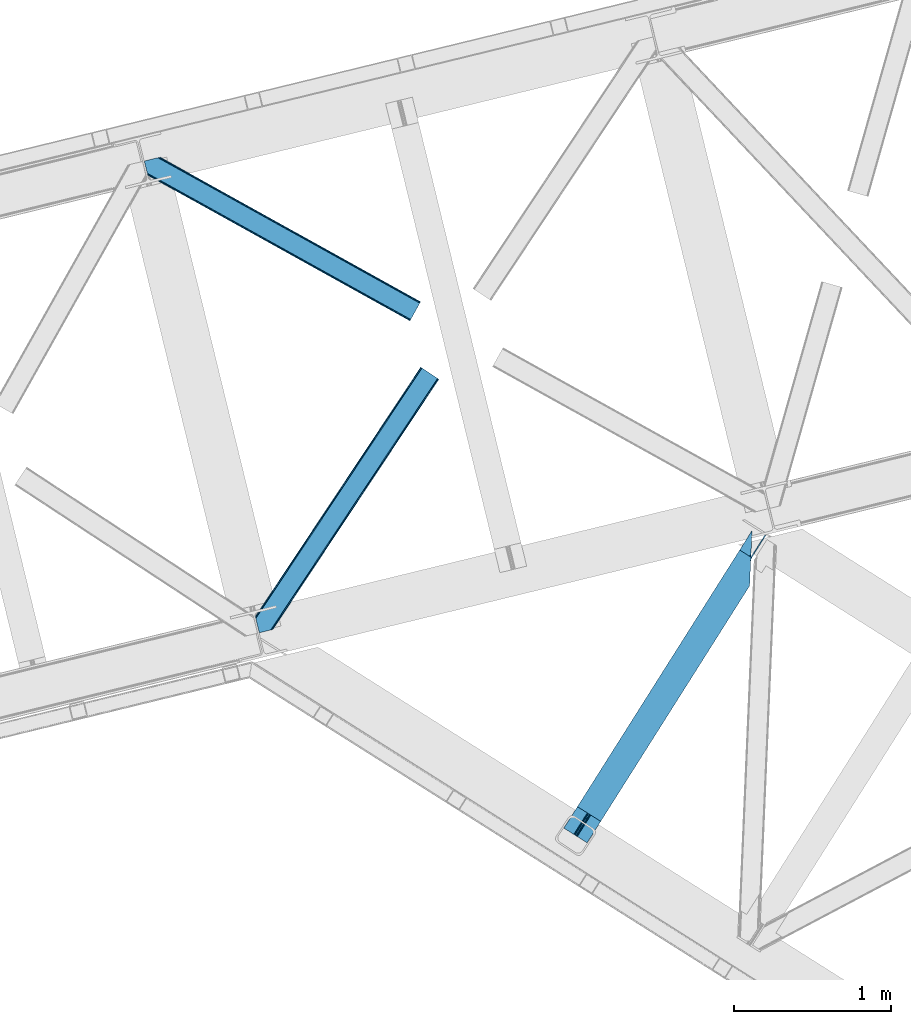
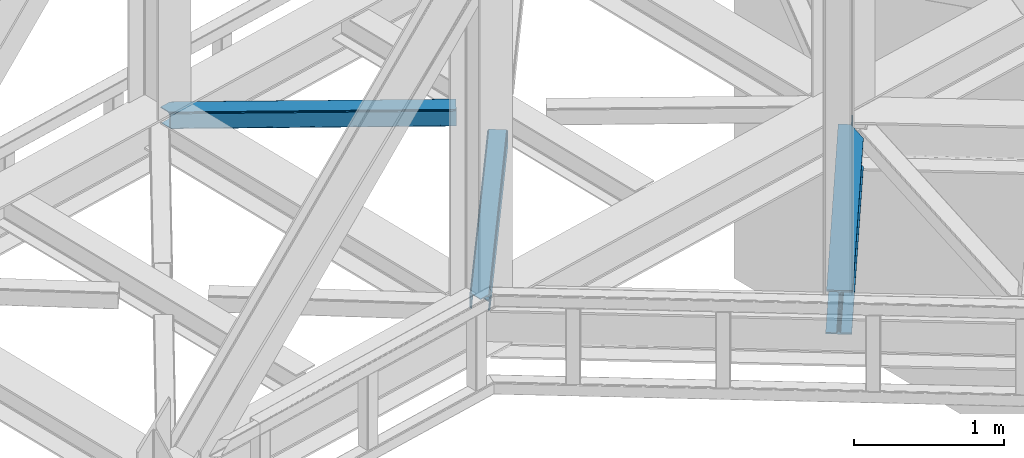
# One storey, part 81 of 93: 2 members, 1 beam.
"""IFC4 building model written with IfcOpenShell, lengths in millimetres."""

from ifc_helpers import new_model, entity, si_unit, converted_unit, derived_unit, direction, frame, origin, place, context, subcontext, project, spatial, triangles, type_object, element, save


model = new_model("IFC4")

# Units and contexts
model_context = context("Model", 3, precision=0.01, world=origin(), true_north=direction((6.12303176911189e-17, 1.0)))
plan_context = context("Plan", 3, precision=0.01, world=origin(), true_north=direction((6.12303176911189e-17, 1.0)))
body_context = subcontext(model_context, "Body", "Model", "MODEL_VIEW")
ifc_project = project(units=[si_unit("LENGTHUNIT", "METRE", prefix="MILLI"), si_unit("AREAUNIT", "SQUARE_METRE"), si_unit("VOLUMEUNIT", "CUBIC_METRE"), converted_unit("PLANEANGLEUNIT", "DEGREE", entity("IfcRatioMeasure", 0.0174532925199433), si_unit("PLANEANGLEUNIT", "RADIAN"), dimensions=[0, 0, 0, 0, 0, 0, 0]), si_unit("MASSUNIT", "GRAM", prefix="KILO"), derived_unit("MASSDENSITYUNIT", [(si_unit("MASSUNIT", "GRAM", prefix="KILO"), 1), (si_unit("LENGTHUNIT", "METRE"), -3)]), derived_unit("MOMENTOFINERTIAUNIT", [(si_unit("LENGTHUNIT", "METRE"), 4)]), si_unit("TIMEUNIT", "SECOND"), si_unit("FREQUENCYUNIT", "HERTZ"), si_unit("THERMODYNAMICTEMPERATUREUNIT", "DEGREE_CELSIUS"), derived_unit("THERMALTRANSMITTANCEUNIT", [(si_unit("MASSUNIT", "GRAM", prefix="KILO"), 1), (si_unit("THERMODYNAMICTEMPERATUREUNIT", "KELVIN"), -1), (si_unit("TIMEUNIT", "SECOND"), -3)]), derived_unit("VOLUMETRICFLOWRATEUNIT", [(si_unit("LENGTHUNIT", "METRE"), 3), (si_unit("TIMEUNIT", "SECOND"), -1)]), derived_unit("MASSFLOWRATEUNIT", [(si_unit("MASSUNIT", "GRAM", prefix="KILO"), 1), (si_unit("TIMEUNIT", "SECOND"), -1)]), derived_unit("ROTATIONALFREQUENCYUNIT", [(si_unit("TIMEUNIT", "SECOND"), -1)]), si_unit("ELECTRICCURRENTUNIT", "AMPERE"), si_unit("ELECTRICVOLTAGEUNIT", "VOLT"), si_unit("POWERUNIT", "WATT"), si_unit("FORCEUNIT", "NEWTON", prefix="KILO"), si_unit("ILLUMINANCEUNIT", "LUX"), si_unit("LUMINOUSFLUXUNIT", "LUMEN"), si_unit("LUMINOUSINTENSITYUNIT", "CANDELA"), derived_unit("USERDEFINED", [(si_unit("MASSUNIT", "GRAM", prefix="KILO"), -1), (si_unit("LENGTHUNIT", "METRE"), -2), (si_unit("TIMEUNIT", "SECOND"), 3), (si_unit("LUMINOUSFLUXUNIT", "LUMEN"), 1)]), derived_unit("LINEARVELOCITYUNIT", [(si_unit("LENGTHUNIT", "METRE"), 1), (si_unit("TIMEUNIT", "SECOND"), -1)]), si_unit("PRESSUREUNIT", "PASCAL"), derived_unit("USERDEFINED", [(si_unit("LENGTHUNIT", "METRE"), -2), (si_unit("MASSUNIT", "GRAM", prefix="KILO"), 1), (si_unit("TIMEUNIT", "SECOND"), -2)]), derived_unit("LINEARFORCEUNIT", [(si_unit("MASSUNIT", "GRAM", prefix="KILO"), 1), (si_unit("LENGTHUNIT", "METRE"), 1), (si_unit("TIMEUNIT", "SECOND"), -2), (si_unit("LENGTHUNIT", "METRE"), -1)]), derived_unit("PLANARFORCEUNIT", [(si_unit("MASSUNIT", "GRAM", prefix="KILO"), 1), (si_unit("LENGTHUNIT", "METRE"), 1), (si_unit("TIMEUNIT", "SECOND"), -2), (si_unit("LENGTHUNIT", "METRE"), -2)])], contexts=[model_context, plan_context])

# Site, building, storey
site_placement = place(None, origin())
site = spatial("IfcSite", under=ifc_project, at=site_placement, CompositionType="ELEMENT")
building_placement = place(site_placement, origin())
building = spatial("IfcBuilding", under=site, at=building_placement, CompositionType="ELEMENT")
storey_placement = place(building_placement, frame((0.0, 0.0, 15900.0)))
storey = spatial("IfcBuildingStorey", under=building, at=storey_placement, CompositionType="ELEMENT", Elevation=15900.0)

# Beam
beam_type = type_object("IfcBeamType", PredefinedType="BEAM")
beam_placement = place(storey_placement, frame((-3471.97848129272, 14954.9604217529, 3440.99967956543)))
element("IfcBeam", 1, at=beam_placement, inside=storey, type_object=beam_type, ObjectType="Steel Beam", PredefinedType="BEAM", context=body_context, shape_type="Tessellation", body=[
    triangles([(1188.72613334656, 1816.41354675293, 231.001016235354), (1188.08329467773, 1793.75679016113, 228.315133666994), (1188.92815589905, 1796.73218994141, 227.02451477051), (1187.41618423462, 1786.02702941895, 231.001016235354), (1190.21528663635, 1815.46941833496, 227.191946411134), (1191.30315628052, 1805.13516540527, 223.385202026369), (1194.96863021851, 1812.46611328125, 221.003952026367), (1191.70894546509, 1814.52645263672, 223.385202026369), (1191.71897392273, 1805.96185913086, 223.115451049805), (163.219397735596, 181.395904541016, 216.999545288087), (1194.53856925964, 1812.73818969727, 216.999545288087), (164.249276733398, 180.744781494141, 223.122427368166), (167.180783843994, 178.891406250001, 228.315133666994), (1187.27709388733, 1782.76792602539, 231.782363891602), (1186.75067253113, 1770.47332763672, 233.000894165041), (171.567144012451, 176.117156982422, 231.782363891602), (176.744734954834, 172.846426391601, 233.000894165041), (1180.87254295349, 1633.92584838867, 233.000894165041), (234.219715118408, 136.50910949707, 233.000894165041), (1188.72613334656, 1816.41354675293, 244.000222778323), (1180.87254295349, 1633.92584838867, 244.000222778323), (234.219715118408, 136.50910949707, 244.000222778323), (1117.61957244873, 1861.36429138184, 244.000222778323), (86.3005462646483, 230.022006225587, 244.000222778323), (1117.61957244873, 1861.36429138184, 233.000894165041), (86.3005462646483, 230.022006225587, 233.000894165041), (1175.09905815125, 1825.02813720703, 233.000894165041), (143.779886627197, 193.685852050781, 233.000894165041), (1187.59422569275, 1817.12978210449, 223.122427368166), (1188.62410469055, 1816.47865905762, 216.999545288087), (157.300572967529, 185.135211181641, 216.999545288087), (156.270693969726, 185.786334228516, 223.122427368166), (1184.66271858215, 1818.98315734863, 228.315133666994), (153.339186859131, 187.639709472656, 228.315133666994), (1180.27214355469, 1821.75624389649, 231.782363891602), (148.953117370605, 190.413958740235, 231.782363891602), (1188.62410469055, 1816.47865905762, 204.000338745118), (1194.53856925964, 1812.73818969727, 204.000338745118), (163.219397735596, 181.395904541016, 204.000338745118), (157.300572967529, 185.135211181641, 204.000338745118), (1284.44601745605, 1954.95276489258, 203.000399780274), (1278.52704734802, 1958.6920715332, 203.000399780274), (1195.07443771362, 1813.58348693848, 203.000399780274), (1189.15546760559, 1817.32395629883, 203.000399780274), (1284.44601745605, 1954.95276489258, 120.000814819337), (1278.52704734802, 1958.6920715332, 120.000814819337), (162.88715057373, 180.872680664063, 203.058535766602), (156.76921005249, 184.291076660156, 203.000399780274), (76.9188514709472, 44.8867950439453, 203.000399780274), (71.0000267028809, 48.626101684571, 203.000399780274), (1200.5501209259, 1835.34494934082, 120.000814819337), (1199.94579734802, 1821.28883056641, 120.000814819337), (1196.02728652954, 1828.19306030274, 119.163656616212), (1195.42281761169, 1814.13694152832, 119.163656616212), (1192.19612503052, 1822.13180236816, 116.778918457032), (1191.59180145264, 1808.07568359375, 116.778918457032), (1189.63639755249, 1818.08088684082, 113.210531616212), (1189.03192863464, 1804.02476806641, 113.210531616212), (1188.73383636475, 1816.65771789551, 109.000323486329), (1188.12951278687, 1802.6015991211, 109.000323486329), (1188.95184631348, 1817.00072021484, 203.077139282228), (1188.73383636475, 1816.65771789551, 27.0006774902358), (71.0000267028809, 48.626101684571, 27.0006774902358), (1189.59076080322, 1836.49139099121, 12.2178588867209), (1190.11718215942, 1848.78598937988, 11.0004913330085), (57.4793403625486, 57.1779052734382, 11.0004913330085), (62.6525711059571, 53.9048492431648, 12.2178588867209), (1189.13977088928, 1826.06760864258, 15.6862518310554), (67.0432914733888, 51.1317626953132, 15.6862518310554), (1188.84124259949, 1819.10291748047, 20.877795410157), (69.9747985839845, 49.2783874511715, 20.877795410157), (1195.99080619812, 1985.3323059082, 11.0004913330085), (0.0, 93.5140594482418, 11.0004913330085), (1195.99080619812, 1985.3323059082, 0.0), (0.0, 93.5140594482418, 0.0), (1180.87254295349, 1633.92584838867, 0.0), (147.91916885376, 0.0, 0.0), (85.2665977478027, 39.6080474853516, 12.2178588867209), (80.8802375793457, 42.3822967529304, 15.6862518310554), (76.9188514709472, 44.8867950439453, 27.0006774902358), (77.94873046875, 44.2356719970703, 20.877795410157), (90.4441886901855, 36.3373168945309, 11.0004913330085), (147.91916885376, 0.0, 11.0004913330085), (1187.27709388733, 1782.76792602539, 12.2178588867209), (1186.75067253113, 1770.47332763672, 11.0004913330085), (1188.02661209106, 1800.15639953613, 20.877795410157), (1187.7279384613, 1793.19170837402, 15.6862518310554), (1188.12951278687, 1802.6015991211, 27.0006774902358), (1180.87254295349, 1633.92584838867, 11.0004913330085)], [[1, 2, 3], [1, 4, 2], [5, 3, 6], [7, 8, 9], [6, 9, 8], [6, 8, 5], [3, 5, 1], [10, 11, 9], [11, 7, 9], [12, 9, 6], [6, 13, 12], [6, 3, 13], [2, 13, 3], [13, 4, 14], [13, 2, 4], [14, 15, 16], [17, 16, 15], [14, 16, 13], [9, 12, 10], [15, 18, 17], [19, 17, 18], [20, 14, 4], [14, 20, 15], [4, 1, 20], [21, 15, 20], [21, 18, 15], [18, 21, 22], [22, 19, 18], [21, 23, 24], [23, 21, 20], [24, 22, 21], [23, 25, 24], [26, 24, 25], [25, 27, 28], [28, 26, 25], [29, 30, 31], [31, 32, 29], [33, 29, 34], [32, 34, 29], [35, 33, 34], [34, 36, 35], [27, 35, 36], [36, 28, 27], [1, 35, 20], [8, 7, 11], [30, 11, 37], [37, 11, 38], [8, 29, 5], [11, 30, 8], [5, 33, 1], [27, 20, 35], [33, 5, 29], [30, 29, 8], [33, 35, 1], [27, 23, 20], [23, 27, 25], [13, 16, 36], [17, 22, 24], [19, 22, 17], [16, 17, 28], [10, 12, 32], [12, 13, 32], [39, 10, 40], [34, 13, 36], [24, 28, 17], [28, 36, 16], [24, 26, 28], [32, 31, 10], [31, 40, 10], [34, 32, 13], [41, 42, 43], [44, 43, 42], [41, 45, 42], [46, 42, 45], [47, 48, 49], [50, 49, 48], [46, 45, 51], [52, 51, 45], [51, 52, 53], [54, 53, 52], [53, 54, 55], [56, 55, 54], [57, 55, 56], [56, 58, 57], [59, 57, 58], [58, 60, 59], [57, 37, 61], [57, 61, 55], [53, 55, 61], [42, 46, 51], [51, 61, 42], [61, 51, 53], [62, 48, 59], [59, 48, 31], [63, 48, 62], [63, 50, 48], [31, 37, 59], [59, 37, 57], [31, 30, 37], [64, 65, 66], [66, 67, 64], [68, 64, 67], [67, 69, 68], [70, 68, 69], [69, 71, 70], [62, 70, 71], [71, 63, 62], [65, 72, 73], [73, 66, 65], [72, 74, 75], [75, 73, 72], [74, 76, 75], [77, 75, 76], [78, 79, 67], [80, 71, 81], [79, 81, 69], [80, 49, 63], [82, 75, 77], [77, 83, 82], [82, 78, 66], [67, 79, 69], [71, 80, 63], [50, 63, 49], [71, 69, 81], [75, 82, 66], [67, 66, 78], [73, 75, 66], [68, 64, 84], [65, 74, 76], [72, 74, 65], [64, 65, 85], [62, 70, 86], [70, 68, 87], [59, 62, 88], [87, 68, 84], [76, 85, 65], [85, 84, 64], [76, 89, 85], [86, 88, 62], [88, 60, 59], [87, 86, 70], [86, 88, 80], [80, 81, 86], [87, 86, 81], [81, 79, 87], [84, 87, 79], [79, 78, 84], [85, 84, 78], [78, 82, 85], [89, 85, 82], [82, 83, 89], [76, 89, 77], [83, 77, 89]]),
])

# Members
member_type_1 = type_object("IfcMemberType", PredefinedType="BRACE")
member_1_placement = place(storey_placement, frame((-5433.35323791504, 16290.2998443604, 3510.01988525391)))
element("IfcMember", 2, at=member_1_placement, inside=storey, type_object=member_type_1, ObjectType="Steel Horizontal Brace", PredefinedType="BRACE", context=body_context, shape_type="Tessellation", body=[
    triangles([(1167.55605926514, 1611.29350891113, 17.5000946044929), (1167.55605926514, 1611.29350891113, 122.499499511719), (112.764628601074, 21.275445556641, 17.5000946044929), (112.764628601074, 21.275445556641, 122.499499511719), (1166.44769668579, 1612.03067321777, 129.196765136719), (110.858349609375, 20.810357666016, 129.196765136719), (1163.28451766968, 1614.12705688477, 134.87548828125), (105.426704406738, 19.486019897462, 134.87548828125), (1158.55573654175, 1617.26640014649, 138.668280029298), (97.3022003173828, 17.5059082031257, 138.668280029298), (1152.97613525391, 1620.96849975586, 140.000756835936), (87.713832092285, 15.1688415527351, 140.000756835936), (5.64326019287091, 81.3950317382823, 140.000756835936), (1065.47537155151, 1679.01263122559, 140.000756835936), (25.4839096069336, 0.0, 140.000756835936), (1059.89577026367, 1682.71473083496, 138.668280029298), (3.48350830078107, 90.2537933349613, 138.668280029298), (1055.16698913574, 1685.85407409668, 134.87548828125), (1.65280609130878, 97.7649627685551, 134.87548828125), (1052.00381011963, 1687.95045776367, 129.196765136719), (0.42962493896448, 102.7832611084, 129.196765136719), (1050.89573822022, 1688.68762207031, 122.499499511719), (0.0, 104.544781494142, 122.499499511719), (1050.89573822022, 1688.68762207031, 17.5000946044929), (0.0, 104.544781494142, 17.5000946044929), (1166.44769668579, 1612.03067321777, 10.8039916992202), (1163.28451766968, 1614.12705688477, 5.12643127441333), (159.822802734375, 95.9557708740231, 9.25873718261573), (160.257078552246, 97.3742889404293, 8.50064392089917), (159.407711791992, 100.858959960939, 5.12643127441333), (110.469419860839, 20.7150146484382, 10.8702667236321), (109.995030212403, 20.5999053955074, 9.50058288574292), (1152.97613525391, 1620.96849975586, 0.0), (1158.55573654175, 1617.26640014649, 1.33247680664135), (155.417839050293, 117.227728271484, 0.0), (157.577009582519, 108.368966674805, 1.33247680664135), (1065.47537155151, 1679.01263122559, 0.0), (121.558859252929, 256.129714965822, 0.0), (155.314356994629, 113.429122924807, 9.50058288574292), (90.5967956542972, 15.8711242675781, 9.50058288574292), (155.425978088379, 114.267443847655, 9.29594421386719), (155.539343261718, 115.1185546875, 9.08781738281323), (160.118714904786, 96.9219909667972, 8.74248962402271), (155.650964355469, 115.956875610353, 8.8831787109375), (155.446325683593, 117.1102935791, 8.50064392089917), (1152.72004623413, 1621.13593139648, 8.3320495605476), (1147.14073562622, 1624.83803100586, 7.00073547363354), (153.160418701172, 126.488790893554, 7.00073547363354), (1157.45347824097, 1617.99775085449, 12.1260040283196), (95.4092926025387, 17.0443084716808, 12.1260040283196), (1161.72501983643, 1615.16420288086, 24.5008300781265), (1160.61200637817, 1615.90020446777, 17.8035644531265), (102.742565917969, 18.8325714111324, 24.5008300781265), (100.835705566406, 18.3674835205074, 17.8035644531265), (1161.72501983643, 1615.16420288086, 115.499926757813), (102.742565917969, 18.8325714111324, 115.499926757813), (100.835705566406, 18.3674835205074, 122.197192382813), (87.2801376342777, 15.0630340576172, 131.668707275392), (77.6917694091799, 12.7259674072266, 133.00118408203), (25.4839096069336, 0.0, 133.00118408203), (95.4092926025387, 17.0443084716808, 127.875915527344), (1147.14073562622, 1624.83803100586, 133.00118408203), (1152.72004623413, 1621.13593139648, 131.668707275392), (1157.45347824097, 1617.99775085449, 127.875915527344), (1160.61200637817, 1615.90020446777, 122.197192382813), (7.90068054199219, 72.1351318359375, 133.00118408203), (1071.3107711792, 1675.14309997558, 133.00118408203), (1056.72648696899, 1684.81692810058, 115.499926757813), (1057.83950042725, 1684.0820892334, 122.197192382813), (2.25742034912128, 95.2848815917987, 115.499926757813), (2.68704528808576, 93.5233612060547, 122.197192382813), (1060.99802856445, 1681.98338012695, 127.875915527344), (3.91022644043005, 88.505062866212, 127.875915527344), (1065.73146057129, 1678.84636230469, 131.668707275392), (5.74092864990234, 80.9938934326183, 131.668707275392), (1060.99802856445, 1681.98338012695, 12.1260040283196), (1059.89577026367, 1682.71473083496, 1.33247680664135), (1055.16698913574, 1685.85407409668, 5.12643127441333), (1071.3107711792, 1675.14309997558, 7.00073547363354), (1065.73146057129, 1678.84636230469, 8.3320495605476), (1056.72648696899, 1684.81692810058, 24.5008300781265), (1052.00381011963, 1687.95045776367, 10.8039916992202), (1057.83950042725, 1684.0820892334, 17.8035644531265), (2.25742034912128, 95.2848815917987, 24.5008300781265), (123.816279602051, 246.869815063475, 7.00073547363354), (2.88121948242224, 92.7245727539066, 16.5001556396492), (2.77483062744159, 93.1629180908203, 17.8698394775383), (0.0093017578128638, 104.50757446289, 16.5001556396492), (119.399688720703, 264.988476562501, 1.33247680664135), (121.662922668457, 255.702996826172, 8.41343994140698), (117.568986511231, 272.499645996095, 5.12643127441333), (116.719619750977, 275.983154296877, 8.50064392089917), (4.73924560546857, 108.865447998049, 10.8714294433594), (115.787118530274, 275.584341430664, 9.50058288574292), (5.89266357421911, 109.927011108399, 9.50058288574292), (7.20479278564471, 93.4687133789066, 12.1260040283196), (120.157200622559, 257.658691406252, 9.50058288574292), (121.184463500977, 256.801766967774, 8.80643920898365), (10.2621643066404, 92.0013610839851, 9.50058288574292)], [[1, 2, 3], [4, 3, 2], [2, 5, 4], [6, 4, 5], [5, 7, 6], [8, 6, 7], [7, 9, 8], [10, 8, 9], [9, 11, 10], [12, 10, 11], [11, 13, 12], [11, 14, 13], [13, 15, 12], [14, 16, 17], [17, 13, 14], [16, 18, 19], [19, 17, 16], [18, 20, 21], [21, 19, 18], [20, 22, 23], [23, 21, 20], [22, 24, 23], [25, 23, 24], [26, 1, 3], [27, 28, 29], [29, 30, 27], [26, 31, 28], [28, 27, 26], [31, 32, 28], [33, 34, 35], [36, 35, 34], [34, 27, 36], [30, 36, 27], [3, 31, 26], [37, 33, 38], [35, 38, 33], [39, 28, 32], [32, 40, 39], [39, 41, 28], [41, 42, 43], [42, 44, 43], [44, 45, 29], [46, 47, 48], [49, 46, 45], [45, 44, 49], [49, 42, 41], [42, 49, 44], [41, 39, 49], [49, 39, 50], [40, 50, 39], [48, 45, 46], [51, 52, 53], [54, 53, 52], [52, 49, 54], [50, 54, 49], [55, 51, 53], [53, 56, 55], [57, 4, 6], [58, 10, 12], [15, 59, 12], [59, 15, 60], [59, 58, 12], [61, 10, 58], [61, 57, 8], [8, 10, 61], [6, 8, 57], [53, 3, 4], [50, 32, 54], [57, 56, 4], [50, 40, 32], [53, 54, 3], [56, 53, 4], [31, 3, 54], [54, 32, 31], [62, 63, 58], [58, 59, 62], [63, 64, 61], [61, 58, 63], [64, 65, 57], [57, 61, 64], [65, 55, 56], [56, 57, 65], [62, 66, 67], [66, 62, 59], [60, 66, 59], [68, 69, 70], [71, 70, 69], [69, 72, 71], [73, 71, 72], [72, 74, 73], [75, 73, 74], [74, 67, 75], [66, 75, 67], [26, 49, 52], [51, 2, 1], [26, 52, 1], [26, 27, 49], [52, 51, 1], [49, 27, 34], [47, 33, 37], [33, 46, 34], [46, 33, 47], [46, 49, 34], [5, 64, 7], [55, 2, 51], [2, 65, 5], [65, 2, 55], [5, 65, 64], [11, 62, 14], [9, 7, 64], [64, 63, 9], [63, 62, 11], [11, 9, 63], [76, 77, 78], [37, 79, 47], [37, 80, 79], [80, 37, 77], [76, 80, 77], [81, 24, 22], [82, 83, 76], [78, 82, 76], [83, 82, 24], [81, 83, 24], [16, 72, 18], [14, 62, 67], [67, 74, 14], [74, 72, 16], [16, 14, 74], [20, 18, 72], [22, 68, 81], [69, 22, 20], [22, 69, 68], [69, 20, 72], [81, 68, 84], [70, 84, 68], [47, 79, 85], [85, 48, 47], [75, 66, 13], [66, 15, 13], [66, 60, 15], [17, 75, 13], [73, 17, 19], [73, 75, 17], [86, 87, 88], [23, 70, 71], [71, 19, 21], [19, 71, 73], [21, 23, 71], [23, 84, 70], [25, 88, 87], [25, 84, 23], [84, 25, 87], [85, 38, 48], [89, 90, 91], [90, 89, 38], [91, 90, 92], [38, 85, 90], [48, 38, 35], [36, 45, 35], [45, 36, 30], [35, 45, 48], [30, 29, 45], [24, 82, 93], [93, 25, 24], [94, 93, 82], [94, 95, 93], [78, 91, 92], [92, 82, 78], [92, 94, 82], [78, 77, 91], [89, 91, 77], [77, 37, 89], [38, 89, 37], [93, 88, 25], [83, 81, 84], [83, 86, 96], [83, 87, 86], [80, 97, 98], [76, 96, 97], [97, 80, 76], [96, 99, 97], [79, 80, 90], [90, 85, 79], [96, 76, 83], [84, 87, 83], [95, 96, 93], [95, 99, 96], [96, 88, 93], [86, 88, 96], [94, 97, 95], [99, 95, 97]]),
])
member_type_2 = type_object("IfcMemberType", PredefinedType="BRACE")
member_2_placement = place(storey_placement, frame((-6138.83285064697, 18272.4951324463, 3510.01988525391)))
element("IfcMember", 3, at=member_2_placement, inside=storey, type_object=member_type_2, ObjectType="Steel Horizontal Brace", PredefinedType="BRACE", context=body_context, shape_type="Tessellation", body=[
    triangles([(1747.75785369873, 107.098114013672, 140.000756835936), (1751.00765533447, 112.952407836914, 138.668280029298), (86.0110290527336, 1037.46574401855, 138.668280029298), (76.4226608276367, 1035.12867736816, 140.000756835936), (1753.76620788574, 117.917221069336, 134.87548828125), (94.1355331420891, 1039.44585571289, 134.87548828125), (1755.6050491333, 121.232135009766, 129.196765136719), (99.5665969848633, 1040.77019348145, 129.196765136719), (1756.25442810059, 122.398342895507, 122.499499511719), (101.473457336426, 1041.23528137207, 122.499499511719), (1756.25442810059, 122.398342895507, 17.5000946044929), (101.473457336426, 1041.23528137207, 17.5000946044929), (1696.78712768555, 15.3002288818352, 140.000756835936), (16.6437515258785, 948.220028686523, 140.000756835936), (0.0, 1016.49958190918, 140.000756835936), (1688.29055328369, 0.0, 122.499499511719), (1688.935572052, 1.16504516601708, 129.196765136719), (22.2870117187495, 925.070278930663, 122.499499511719), (21.857386779785, 926.831799316406, 129.196765136719), (1690.77906417847, 4.48112182617115, 134.87548828125), (20.6342056274407, 931.85009765625, 134.87548828125), (1693.5326751709, 9.44477233886937, 138.668280029298), (18.8035034179684, 939.361267089844, 138.668280029298), (1688.29055328369, 0.0, 17.5000946044929), (22.2870117187495, 925.070278930663, 17.5000946044929), (1753.76620788574, 117.917221069336, 5.12643127441333), (1751.00765533447, 112.952407836914, 1.33247680664135), (163.947550964355, 994.188153076171, 1.33247680664135), (162.329626464843, 1000.82728271484, 4.50088806152417), (1755.6050491333, 121.232135009766, 10.8039916992202), (161.571533203125, 1001.83419799805, 5.00085754394604), (160.809370422363, 1002.84111328125, 5.50082702636792), (99.5665969848633, 1040.77019348145, 10.8039916992202), (94.6552688598631, 1039.57259216309, 5.50082702636792), (1747.75785369873, 107.098114013672, 0.0), (166.107302856445, 985.329391479492, 0.0), (1696.78712768555, 15.3002288818352, 0.0), (199.965701293945, 846.428567504885, 0.0), (203.74395904541, 830.930676269531, 4.50088806152417), (202.125453186035, 837.568643188479, 1.33247680664135), (22.0515609741205, 926.03533630371, 12.5003997802742), (23.5985595703123, 926.191140747073, 10.9621215820298), (1688.935572052, 1.16504516601708, 10.8039916992202), (202.882965087891, 830.238858032226, 5.50082702636792), (1690.77906417847, 4.48112182617115, 5.12643127441333), (29.0836898803709, 926.742269897462, 5.50082702636792), (1693.5326751709, 9.44477233886937, 1.33247680664135), (6.80074768066333, 1018.15762023926, 5.50082702636792), (20.9359313964842, 953.845266723634, 7.00073547363354), (21.5068267822262, 945.865521240234, 8.3320495605476), (5.34560394287109, 1017.80299072266, 7.00073547363354), (18.4942199707029, 940.629794311524, 12.5003997802742), (1700.1831413269, 21.4196228027358, 7.00073547363354), (66.4005981445307, 1032.68580322266, 7.00073547363354), (1744.36184005737, 100.978720092775, 7.00073547363354), (1694.17478713989, 10.6005157470718, 12.1260040283196), (1696.93333969116, 15.5653289794936, 8.3320495605476), (19.5999664306637, 936.091699218752, 17.8035644531265), (1691.69092712402, 6.12055664062427, 24.5008300781265), (1692.33594589233, 7.28443908691406, 17.8035644531265), (20.0295913696282, 934.33017883301, 24.5008300781265), (1747.61164169311, 106.833013916017, 8.3320495605476), (75.9889663696285, 1035.02286987305, 8.3320495605476), (1750.36554336548, 111.796664428712, 12.1260040283196), (84.1175399780268, 1037.00414428711, 12.1260040283196), (1752.20903549194, 115.112741088869, 17.8035644531265), (89.5445343017573, 1038.32731933594, 17.8035644531265), (1752.85405426025, 116.277786254883, 24.5008300781265), (91.4560455322262, 1038.79240722656, 24.5008300781265), (1752.85405426025, 116.277786254883, 115.499926757813), (91.4560455322262, 1038.79240722656, 115.499926757813), (84.1175399780268, 1037.00414428711, 127.875915527344), (75.9889663696285, 1035.02286987305, 131.668707275392), (89.5445343017573, 1038.32731933594, 122.197192382813), (66.4005981445307, 1032.68580322266, 133.00118408203), (0.0, 1016.49958190918, 133.00118408203), (1752.20903549194, 115.112741088869, 122.197192382813), (1750.36554336548, 111.796664428712, 127.875915527344), (1747.61164169311, 106.833013916017, 131.668707275392), (1744.36184005737, 100.978720092775, 133.00118408203), (1694.17478713989, 10.6005157470718, 127.875915527344), (1700.1831413269, 21.4196228027358, 133.00118408203), (1696.93333969116, 15.5653289794936, 131.668707275392), (1691.69092712402, 6.12055664062427, 115.499926757813), (1692.33594589233, 7.28443908691406, 122.197192382813), (19.5999664306637, 936.091699218752, 122.197192382813), (18.3767852783203, 941.109997558593, 127.875915527344), (20.0295913696282, 934.33017883301, 115.499926757813), (16.5460830688471, 948.621166992187, 131.668707275392), (14.3869125366209, 957.479928588869, 133.00118408203)], [[1, 2, 3], [3, 4, 1], [2, 5, 6], [6, 3, 2], [5, 7, 8], [8, 6, 5], [7, 9, 10], [10, 8, 7], [9, 11, 10], [12, 10, 11], [13, 4, 14], [4, 13, 1], [15, 14, 4], [16, 17, 18], [19, 18, 17], [17, 20, 19], [21, 19, 20], [20, 22, 21], [23, 21, 22], [22, 13, 23], [14, 23, 13], [24, 16, 25], [18, 25, 16], [26, 27, 28], [28, 29, 26], [30, 26, 31], [30, 32, 33], [34, 33, 32], [29, 31, 26], [27, 35, 36], [36, 28, 27], [11, 30, 12], [33, 12, 30], [35, 37, 38], [38, 36, 35], [29, 36, 38], [36, 29, 28], [38, 39, 29], [39, 38, 40], [24, 41, 42], [24, 25, 41], [43, 42, 44], [44, 45, 43], [42, 46, 44], [47, 45, 44], [37, 47, 40], [40, 38, 37], [39, 40, 47], [42, 43, 24], [46, 34, 32], [34, 46, 48], [32, 44, 46], [46, 49, 48], [49, 46, 50], [51, 48, 49], [52, 50, 46], [42, 41, 52], [42, 52, 46], [53, 54, 49], [54, 53, 55], [51, 49, 54], [56, 57, 50], [56, 52, 58], [59, 60, 61], [58, 61, 60], [58, 60, 56], [50, 52, 56], [57, 53, 50], [49, 50, 53], [55, 62, 63], [63, 54, 55], [62, 64, 65], [65, 63, 62], [64, 66, 67], [67, 65, 64], [66, 68, 69], [69, 67, 66], [68, 70, 71], [71, 69, 68], [72, 73, 3], [6, 72, 3], [74, 6, 8], [74, 10, 71], [6, 74, 72], [10, 74, 8], [73, 4, 3], [15, 75, 76], [15, 4, 75], [73, 75, 4], [10, 69, 71], [34, 65, 67], [67, 69, 12], [12, 69, 10], [67, 33, 34], [33, 67, 12], [48, 54, 34], [54, 63, 34], [63, 65, 34], [48, 51, 54], [70, 77, 71], [74, 71, 77], [77, 78, 74], [72, 74, 78], [78, 79, 72], [73, 72, 79], [79, 80, 73], [75, 73, 80], [7, 78, 77], [70, 11, 9], [7, 77, 9], [7, 5, 78], [77, 70, 9], [78, 5, 2], [80, 1, 13], [1, 79, 2], [79, 1, 80], [79, 78, 2], [30, 64, 26], [68, 11, 70], [11, 66, 30], [66, 11, 68], [30, 66, 64], [35, 55, 37], [27, 26, 64], [64, 62, 27], [62, 55, 35], [35, 27, 62], [81, 22, 20], [13, 82, 80], [13, 83, 82], [83, 13, 22], [81, 83, 22], [84, 16, 24], [17, 85, 81], [20, 17, 81], [85, 17, 16], [84, 85, 16], [47, 56, 45], [37, 55, 53], [53, 57, 37], [57, 56, 47], [47, 37, 57], [43, 45, 56], [24, 59, 84], [60, 24, 43], [24, 60, 59], [60, 43, 56], [86, 21, 87], [88, 61, 18], [19, 86, 18], [86, 19, 21], [86, 88, 18], [61, 25, 18], [58, 52, 41], [41, 25, 58], [61, 58, 25], [89, 23, 14], [15, 90, 14], [76, 90, 15], [89, 87, 23], [23, 87, 21], [90, 89, 14], [75, 82, 90], [75, 80, 82], [90, 76, 75], [84, 59, 61], [61, 88, 84], [82, 83, 89], [89, 90, 82], [83, 81, 87], [87, 89, 83], [81, 85, 86], [86, 87, 81], [85, 84, 88], [88, 86, 85]]),
])

save(model, "model.ifc")
